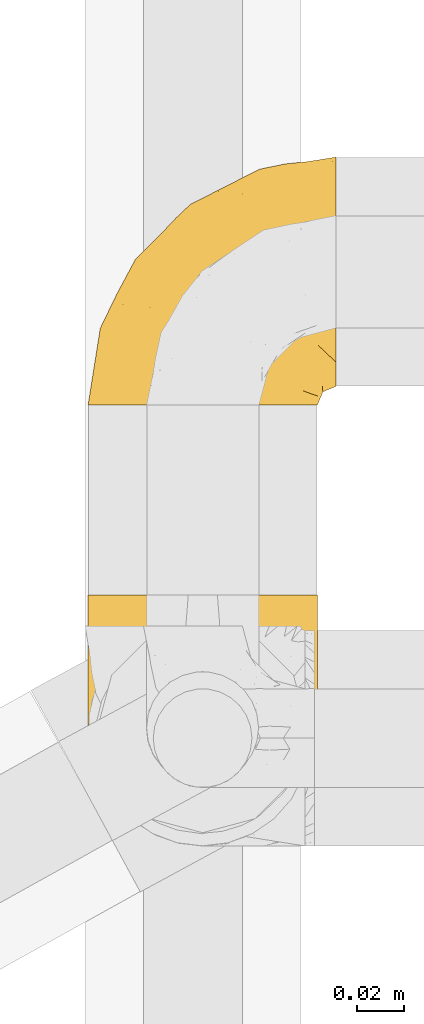
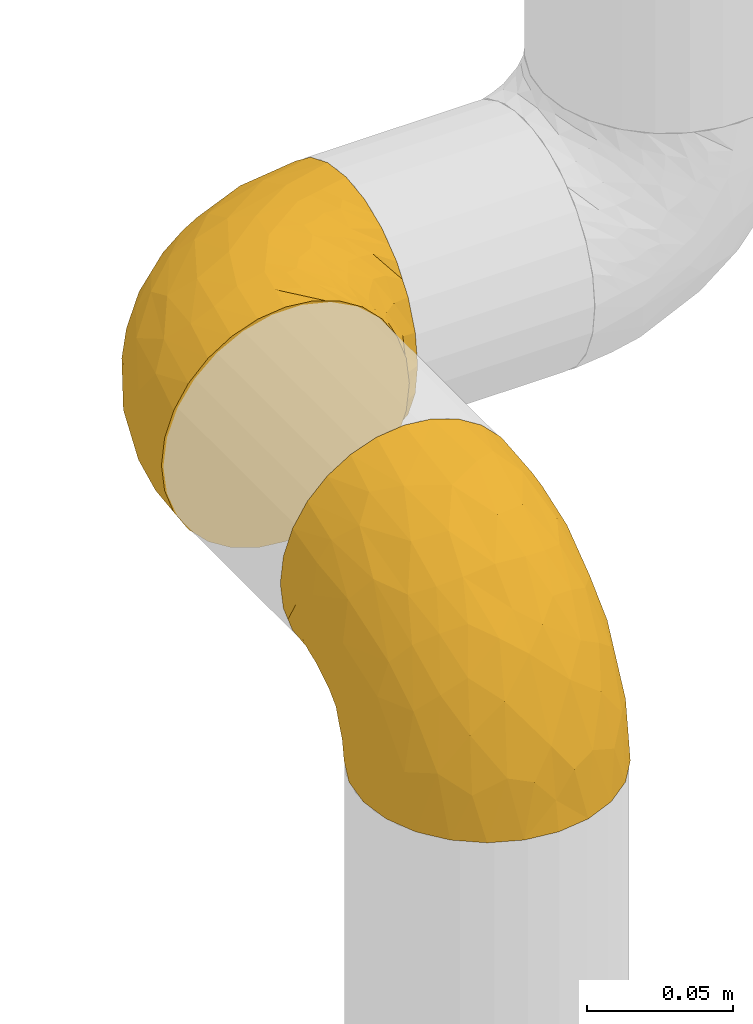
# One storey, part 168 of 827: 2 coverings.
"""IFC2X3 building model written with IfcOpenShell, lengths in millimetres."""

from ifc_helpers import new_model, entity, si_unit, converted_unit, derived_unit, direction, frame, origin, place, context, subcontext, project, spatial, faceted_brep, element, save


model = new_model("IFC2X3")

# Units and contexts
model_context = context("Model", 3, precision=0.01, world=origin(), true_north=direction((6.12303176911189e-17, 1.0)))
body_context = subcontext(model_context, "Body", "Model", "MODEL_VIEW")
ifc_project = project(units=[si_unit("LENGTHUNIT", "METRE", prefix="MILLI"), si_unit("AREAUNIT", "SQUARE_METRE"), si_unit("VOLUMEUNIT", "CUBIC_METRE"), converted_unit("PLANEANGLEUNIT", "DEGREE", entity("IfcRatioMeasure", 0.0174532925199433), si_unit("PLANEANGLEUNIT", "RADIAN"), dimensions=[0, 0, 0, 0, 0, 0, 0]), si_unit("MASSUNIT", "GRAM", prefix="KILO"), derived_unit("MASSDENSITYUNIT", [(si_unit("MASSUNIT", "GRAM", prefix="KILO"), 1), (si_unit("LENGTHUNIT", "METRE"), -3)]), derived_unit("MOMENTOFINERTIAUNIT", [(si_unit("LENGTHUNIT", "METRE"), 4)]), si_unit("TIMEUNIT", "SECOND"), si_unit("FREQUENCYUNIT", "HERTZ"), si_unit("THERMODYNAMICTEMPERATUREUNIT", "DEGREE_CELSIUS"), derived_unit("THERMALTRANSMITTANCEUNIT", [(si_unit("MASSUNIT", "GRAM", prefix="KILO"), 1), (si_unit("THERMODYNAMICTEMPERATUREUNIT", "KELVIN"), -1), (si_unit("TIMEUNIT", "SECOND"), -3)]), derived_unit("VOLUMETRICFLOWRATEUNIT", [(si_unit("LENGTHUNIT", "METRE"), 3), (si_unit("TIMEUNIT", "SECOND"), -1)]), derived_unit("MASSFLOWRATEUNIT", [(si_unit("MASSUNIT", "GRAM", prefix="KILO"), 1), (si_unit("TIMEUNIT", "SECOND"), -1)]), derived_unit("ROTATIONALFREQUENCYUNIT", [(si_unit("TIMEUNIT", "SECOND"), -1)]), si_unit("ELECTRICCURRENTUNIT", "AMPERE"), si_unit("ELECTRICVOLTAGEUNIT", "VOLT"), si_unit("POWERUNIT", "WATT"), si_unit("FORCEUNIT", "NEWTON", prefix="KILO"), si_unit("ILLUMINANCEUNIT", "LUX"), si_unit("LUMINOUSFLUXUNIT", "LUMEN"), si_unit("LUMINOUSINTENSITYUNIT", "CANDELA"), derived_unit("USERDEFINED", [(si_unit("MASSUNIT", "GRAM", prefix="KILO"), -1), (si_unit("LENGTHUNIT", "METRE"), -2), (si_unit("TIMEUNIT", "SECOND"), 3), (si_unit("LUMINOUSFLUXUNIT", "LUMEN"), 1)]), derived_unit("LINEARVELOCITYUNIT", [(si_unit("LENGTHUNIT", "METRE"), 1), (si_unit("TIMEUNIT", "SECOND"), -1)]), si_unit("PRESSUREUNIT", "PASCAL"), derived_unit("USERDEFINED", [(si_unit("LENGTHUNIT", "METRE"), -2), (si_unit("MASSUNIT", "GRAM", prefix="KILO"), 1), (si_unit("TIMEUNIT", "SECOND"), -2)]), derived_unit("LINEARFORCEUNIT", [(si_unit("MASSUNIT", "GRAM", prefix="KILO"), 1), (si_unit("LENGTHUNIT", "METRE"), 1), (si_unit("TIMEUNIT", "SECOND"), -2), (si_unit("LENGTHUNIT", "METRE"), -1)]), derived_unit("PLANARFORCEUNIT", [(si_unit("MASSUNIT", "GRAM", prefix="KILO"), 1), (si_unit("LENGTHUNIT", "METRE"), 1), (si_unit("TIMEUNIT", "SECOND"), -2), (si_unit("LENGTHUNIT", "METRE"), -2)])], contexts=[model_context])

# Site, building, storey
site_placement = place(None, origin())
site = spatial("IfcSite", under=ifc_project, at=site_placement, CompositionType="ELEMENT")
building_placement = place(site_placement, origin())
building = spatial("IfcBuilding", under=site, at=building_placement, CompositionType="ELEMENT")
storey_placement = place(building_placement, frame((0.0, 0.0, 28200.0)))
storey = spatial("IfcBuildingStorey", under=building, at=storey_placement, Name="08", CompositionType="ELEMENT", Elevation=28200.0)

# Coverings
covering_1_placement = place(storey_placement, frame((35683.5, 12959.74, 2541.4)))
element("IfcCovering", 1, at=covering_1_placement, inside=storey, Name=":ADSK_", ObjectType=":ADSK_", PredefinedType="INSULATION", context=body_context, shape_type="Brep", body=[
    faceted_brep([(1.6, 107.75, 58.6), (2.83, 107.75, 69.54), (6.47, 107.75, 79.93), (12.32, 107.75, 89.25), (20.11, 107.75, 97.03), (29.43, 107.75, 102.88), (39.81, 107.75, 106.51), (50.75, 107.75, 107.75), (61.69, 107.75, 106.51), (72.08, 107.75, 102.87), (81.4, 107.75, 97.02), (89.18, 107.75, 89.23), (95.03, 107.75, 79.91), (98.66, 107.75, 69.53), (99.9, 107.75, 58.6), (99.25, 107.75, 52.89), (98.66, 107.75, 47.65), (96.84, 107.75, 42.46), (95.02, 107.75, 37.26), (89.17, 107.75, 27.94), (81.38, 107.75, 20.16), (72.06, 107.75, 14.31), (61.68, 107.75, 10.68), (50.75, 107.75, 9.45), (39.8, 107.75, 10.68), (29.41, 107.75, 14.32), (20.09, 107.75, 20.17), (12.31, 107.75, 27.96), (6.46, 107.75, 37.28), (4.64, 107.75, 42.47), (2.83, 107.75, 47.66), (2.24, 107.75, 52.89), (1.92, 107.75, 55.75), (63.47, 98.22, 1.6), (75.32, 93.31, 1.6), (80.41, 89.4, 1.6), (85.5, 85.5, 1.6), (89.4, 80.41, 1.6), (93.31, 75.32, 1.6), (95.77, 69.39, 1.6), (98.22, 63.47, 1.6), (99.14, 56.48, 1.6), (99.52, 53.61, 1.6), (99.9, 50.75, 1.6), (98.22, 38.02, 1.6), (93.31, 26.17, 1.6), (85.5, 15.99, 1.6), (75.32, 8.18, 1.6), (63.47, 3.27, 1.6), (50.75, 1.6, 1.6), (38.02, 3.27, 1.6), (26.17, 8.18, 1.6), (15.99, 15.99, 1.6), (8.18, 26.17, 1.6), (3.27, 38.02, 1.6), (1.6, 50.75, 1.6), (2.35, 56.48, 1.6), (3.27, 63.47, 1.6), (5.73, 69.39, 1.6), (8.18, 75.32, 1.6), (12.09, 80.41, 1.6), (15.99, 85.5, 1.6), (21.08, 89.4, 1.6), (26.17, 93.31, 1.6), (38.02, 98.22, 1.6), (50.75, 99.9, 1.6), (42.18, 27.53, 69.96), (28.42, 25.32, 59.59), (37.78, 16.29, 51.96), (50.75, 6.79, 34.4), (42.85, 4.51, 23.37), (50.75, 3.51, 13.68), (24.75, 17.47, 41.52), (33.81, 7.6, 26.26), (22.57, 12.27, 20.18), (7.18, 70.89, 72.33), (2.73, 87.17, 65.88), (3.09, 67.3, 57.55), (6.92, 31.65, 23.76), (11.58, 33.58, 46.5), (5.17, 47.23, 46.57), (2.71, 43.26, 21.17), (1.6, 55.08, 23.41), (1.6, 53.99, 17.92), (1.6, 52.9, 12.43), (1.6, 52.36, 9.72), (1.6, 51.82, 7.01), (14.18, 21.5, 26.77), (5.88, 89.94, 76.59), (41.06, 60.45, 95.55), (36.25, 83.0, 102.57), (28.62, 64.79, 92.89), (1.6, 85.93, 54.26), (1.6, 81.31, 51.17), (1.6, 76.69, 48.08), (1.6, 72.06, 44.99), (1.6, 67.44, 41.9), (10.85, 88.74, 85.16), (38.35, 45.98, 85.97), (9.6, 47.13, 59.58), (26.24, 89.4, 99.5), (50.75, 95.66, 105.83), (19.31, 28.5, 53.59), (16.41, 42.81, 67.0), (24.56, 38.28, 71.56), (50.75, 45.35, 87.47), (50.75, 33.61, 75.73), (18.47, 82.57, 92.24), (1.6, 105.04, 58.06), (1.6, 102.33, 57.52), (1.6, 96.91, 56.44), (1.6, 91.42, 55.35), (14.36, 65.92, 81.33), (20.64, 53.11, 80.35), (2.32, 54.37, 39.44), (50.75, 74.94, 102.55), (1.6, 64.35, 37.28), (1.6, 61.26, 32.65), (1.6, 58.17, 28.03), (50.75, 21.87, 63.99), (33.88, 34.79, 74.55), (29.24, 48.48, 83.62), (50.75, 60.15, 95.01), (50.75, 14.33, 49.19), (2.8, 99.07, 46.96), (2.48, 60.55, 8.77), (2.7, 64.18, 18.28), (3.2, 64.36, 11.68), (32.98, 103.17, 11.79), (24.67, 101.69, 15.69), (2.95, 87.75, 42.49), (2.19, 89.38, 47.41), (17.92, 88.34, 7.94), (12.02, 82.14, 9.27), (25.73, 94.51, 7.98), (16.63, 89.64, 13.4), (25.6, 98.41, 13.04), (36.72, 99.71, 7.36), (10.66, 89.37, 23.46), (6.87, 88.21, 30.46), (11.12, 95.2, 26.54), (10.31, 79.14, 6.76), (12.84, 101.22, 26.46), (17.38, 99.41, 20.77), (9.74, 84.72, 20.68), (4.63, 97.47, 40.26), (50.75, 102.19, 7.15), (42.52, 104.02, 9.28), (3.12, 82.66, 38.78), (17.58, 95.42, 18.27), (3.97, 78.67, 31.78), (5.94, 72.69, 12.75), (2.73, 66.46, 22.96), (6.23, 75.3, 17.55), (3.45, 72.74, 27.63), (10.84, 82.93, 15.23), (7.98, 99.27, 33.25), (7.33, 93.51, 32.43), (2.39, 67.35, 27.9), (75.76, 94.51, 7.97), (90.65, 82.94, 15.22), (83.57, 88.33, 7.93), (84.85, 89.64, 13.38), (71.05, 103.62, 13.12), (98.54, 87.74, 42.49), (99.3, 89.38, 47.4), (99.9, 81.31, 51.17), (96.86, 97.47, 40.24), (84.1, 99.41, 20.76), (99.9, 52.9, 12.43), (99.9, 51.82, 7.01), (99.9, 51.28, 4.31), (88.63, 101.21, 26.44), (90.36, 95.19, 26.52), (98.29, 64.36, 11.68), (95.55, 72.69, 12.75), (89.47, 82.13, 9.27), (95.26, 75.3, 17.55), (91.18, 79.14, 6.76), (93.49, 99.28, 33.21), (94.15, 93.51, 32.41), (99.01, 60.55, 8.77), (98.76, 66.46, 22.96), (98.85, 63.96, 18.48), (99.9, 96.91, 56.44), (98.69, 99.06, 46.95), (64.78, 99.7, 7.36), (99.9, 53.99, 17.92), (99.9, 55.08, 23.41), (62.91, 103.3, 9.85), (99.9, 102.33, 57.52), (99.9, 99.62, 56.98), (99.9, 76.69, 48.08), (98.37, 82.66, 38.78), (83.9, 95.42, 18.25), (99.9, 72.06, 44.99), (97.51, 78.68, 31.74), (94.62, 88.2, 30.45), (98.04, 72.75, 27.63), (91.73, 84.74, 20.65), (99.9, 91.42, 55.35), (99.9, 85.93, 54.26), (75.87, 98.41, 13.03), (90.83, 89.37, 23.44), (99.1, 67.35, 27.9), (99.9, 61.26, 32.65), (99.9, 58.17, 28.03), (99.9, 64.35, 37.28), (99.9, 67.44, 41.9), (99.09, 54.08, 39.74), (58.64, 4.51, 23.37), (87.31, 21.5, 26.77), (89.93, 33.43, 46.18), (82.22, 28.5, 53.54), (76.74, 17.47, 41.53), (73.12, 25.36, 59.61), (95.54, 90.18, 76.79), (98.7, 86.97, 66.11), (98.79, 43.26, 21.17), (63.71, 16.29, 51.96), (67.68, 7.6, 26.26), (78.92, 12.27, 20.18), (94.57, 31.65, 23.76), (72.88, 64.79, 92.88), (65.25, 83.0, 102.57), (60.44, 60.44, 95.54), (76.94, 38.35, 71.63), (67.61, 34.8, 74.55), (94.38, 71.54, 72.51), (59.31, 27.53, 69.96), (83.03, 82.57, 92.23), (90.66, 88.74, 85.15), (80.8, 53.19, 80.45), (72.22, 48.49, 83.65), (98.39, 67.28, 57.57), (92.31, 52.32, 63.68), (63.11, 45.94, 85.95), (75.27, 89.4, 99.49), (87.15, 65.75, 81.23), (96.03, 46.73, 47.07), (85.1, 42.82, 66.99)], [[[0, 1, 2, 3, 4, 5, 6, 7, 8, 9, 10, 11, 12, 13, 14, 15, 16, 17, 18, 19, 20, 21, 22, 23, 24, 25, 26, 27, 28, 29, 30, 31, 32]], [[33, 34, 35, 36, 37, 38, 39, 40, 41, 42, 43, 44, 45, 46, 47, 48, 49, 50, 51, 52, 53, 54, 55, 56, 57, 58, 59, 60, 61, 62, 63, 64, 65]], [[66, 67, 68]], [[69, 70, 71]], [[68, 72, 73]], [[73, 72, 74]], [[75, 76, 77]], [[78, 79, 80]], [[51, 50, 73]], [[81, 82, 83, 84, 85, 86, 55]], [[52, 87, 53]], [[74, 52, 51]], [[2, 1, 88]], [[89, 90, 91]], [[77, 92, 93, 94, 95, 96]], [[55, 54, 81]], [[78, 53, 87]], [[5, 90, 6]], [[88, 76, 75]], [[97, 3, 2]], [[89, 91, 98]], [[99, 80, 79]], [[90, 5, 100]], [[74, 87, 52]], [[100, 5, 4]], [[90, 101, 6]], [[79, 102, 103]], [[102, 67, 104]], [[105, 98, 106]], [[107, 4, 3]], [[76, 0, 108, 109, 110, 111, 92]], [[107, 112, 113]], [[114, 77, 96]], [[89, 115, 90]], [[114, 96, 116, 117, 118, 82]], [[75, 97, 88]], [[119, 66, 68]], [[50, 71, 70]], [[100, 91, 90]], [[99, 77, 80]], [[102, 104, 103]], [[97, 107, 3]], [[80, 81, 78]], [[107, 97, 112]], [[68, 73, 70]], [[66, 98, 120]], [[78, 81, 54]], [[114, 81, 80]], [[53, 78, 54]], [[78, 87, 79]], [[102, 87, 72]], [[79, 103, 99]], [[4, 107, 100]], [[91, 100, 107]], [[88, 97, 2]], [[112, 97, 75]], [[99, 112, 75]], [[103, 104, 113]], [[91, 121, 98]], [[89, 105, 122, 115]], [[101, 90, 115]], [[101, 7, 6]], [[88, 1, 76]], [[0, 76, 1]], [[92, 77, 76]], [[73, 74, 51]], [[87, 74, 72]], [[81, 114, 82]], [[77, 114, 80]], [[87, 102, 79]], [[67, 102, 72]], [[68, 67, 72]], [[67, 120, 104]], [[120, 121, 104]], [[104, 121, 113]], [[121, 120, 98]], [[91, 107, 113]], [[91, 113, 121]], [[103, 113, 112]], [[106, 98, 66]], [[105, 89, 98]], [[106, 66, 119]], [[67, 66, 120]], [[68, 69, 123, 119]], [[50, 49, 71]], [[50, 70, 73]], [[112, 99, 103]], [[77, 99, 75]], [[69, 68, 70]], [[29, 124, 110]], [[84, 83, 125]], [[126, 82, 118]], [[59, 58, 127]], [[25, 128, 129]], [[130, 93, 131]], [[132, 62, 133]], [[134, 135, 136]], [[137, 65, 64]], [[64, 134, 137]], [[138, 139, 140]], [[111, 110, 124, 92]], [[134, 136, 137]], [[134, 64, 63]], [[141, 61, 60]], [[125, 58, 57]], [[142, 143, 140]], [[142, 26, 143]], [[127, 83, 82]], [[28, 124, 29]], [[108, 0, 32, 31, 30, 110, 109]], [[30, 29, 110]], [[135, 144, 138]], [[28, 145, 124]], [[57, 56, 55, 86, 85, 84]], [[146, 147, 23]], [[24, 23, 147]], [[25, 143, 26]], [[95, 94, 148]], [[24, 128, 25]], [[149, 138, 143]], [[124, 145, 131]], [[127, 58, 125]], [[150, 148, 139]], [[127, 126, 151]], [[151, 59, 127]], [[152, 151, 126]], [[153, 154, 155]], [[153, 133, 141]], [[145, 28, 27]], [[142, 156, 27]], [[157, 148, 130]], [[61, 133, 62]], [[134, 132, 135]], [[147, 128, 24]], [[65, 137, 146]], [[146, 137, 147]], [[128, 137, 136]], [[137, 128, 147]], [[128, 136, 129]], [[149, 129, 136]], [[25, 129, 143]], [[158, 152, 117]], [[152, 118, 117]], [[153, 151, 152]], [[158, 116, 154]], [[144, 150, 138]], [[153, 152, 158]], [[133, 153, 155]], [[133, 155, 132]], [[141, 60, 151]], [[135, 132, 155]], [[134, 63, 132]], [[144, 135, 155]], [[135, 138, 149]], [[155, 154, 144]], [[150, 154, 96]], [[154, 150, 144]], [[148, 94, 130]], [[82, 126, 127]], [[118, 152, 126]], [[150, 96, 95]], [[139, 148, 157]], [[150, 95, 148]], [[93, 92, 131]], [[130, 145, 156]], [[130, 94, 93]], [[84, 125, 57]], [[127, 125, 83]], [[140, 139, 157]], [[150, 139, 138]], [[140, 157, 142]], [[138, 140, 143]], [[156, 142, 157]], [[27, 26, 142]], [[130, 156, 157]], [[145, 27, 156]], [[132, 63, 62]], [[124, 131, 92]], [[130, 131, 145]], [[129, 149, 143]], [[135, 149, 136]], [[153, 141, 151]], [[59, 151, 60]], [[133, 61, 141]], [[116, 96, 154]], [[153, 158, 154]], [[158, 117, 116]], [[34, 33, 159]], [[160, 161, 162]], [[22, 21, 163]], [[164, 165, 166]], [[19, 18, 167]], [[168, 21, 20]], [[42, 41, 40, 169, 170, 171, 43]], [[172, 173, 168]], [[174, 38, 175]], [[176, 177, 178]], [[179, 164, 180]], [[40, 181, 169]], [[182, 183, 175]], [[17, 184, 185]], [[65, 146, 186]], [[187, 174, 188]], [[23, 22, 189]], [[174, 39, 38]], [[15, 14, 190, 191, 184, 16]], [[181, 40, 39]], [[192, 193, 164]], [[194, 163, 168]], [[33, 186, 159]], [[180, 173, 172]], [[195, 196, 193]], [[18, 185, 167]], [[173, 180, 197]], [[198, 199, 196]], [[200, 201, 185, 184]], [[184, 17, 16]], [[18, 17, 185]], [[202, 159, 186]], [[194, 168, 203]], [[189, 163, 202]], [[204, 205, 182]], [[187, 181, 174]], [[160, 177, 176]], [[206, 183, 182]], [[206, 182, 205]], [[201, 165, 185]], [[165, 164, 167]], [[172, 179, 180]], [[202, 194, 162]], [[176, 161, 160]], [[65, 186, 33]], [[163, 189, 22]], [[175, 177, 182]], [[174, 183, 188]], [[177, 198, 204]], [[199, 160, 162]], [[198, 207, 204]], [[175, 38, 37]], [[198, 177, 160]], [[178, 177, 175]], [[176, 35, 161]], [[34, 159, 161]], [[162, 161, 159]], [[202, 162, 159]], [[199, 162, 203]], [[196, 199, 203]], [[198, 160, 199]], [[193, 197, 180]], [[208, 198, 196]], [[188, 183, 206]], [[175, 183, 174]], [[193, 192, 195]], [[195, 208, 196]], [[197, 196, 203]], [[180, 164, 193]], [[168, 163, 21]], [[166, 165, 201]], [[166, 192, 164]], [[189, 202, 186]], [[186, 146, 189]], [[23, 189, 146]], [[174, 181, 39]], [[169, 181, 187]], [[196, 197, 193]], [[173, 203, 168]], [[203, 173, 197]], [[172, 168, 20]], [[20, 19, 172]], [[179, 172, 19]], [[19, 167, 179]], [[164, 179, 167]], [[35, 176, 36]], [[35, 34, 161]], [[185, 165, 167]], [[162, 194, 203]], [[163, 194, 202]], [[176, 178, 36]], [[37, 36, 178]], [[175, 37, 178]], [[177, 204, 182]], [[207, 198, 208]], [[207, 205, 204]], [[209, 188, 206, 205, 207, 208]], [[48, 210, 71]], [[211, 212, 213]], [[214, 213, 215]], [[216, 217, 13]], [[218, 43, 171, 170, 169, 187, 188]], [[219, 220, 214]], [[47, 46, 221]], [[210, 48, 220]], [[211, 222, 212]], [[222, 45, 44]], [[221, 220, 47]], [[47, 220, 48]], [[221, 211, 214]], [[223, 224, 225]], [[211, 46, 45]], [[226, 227, 215]], [[43, 218, 44]], [[217, 216, 228]], [[219, 215, 229]], [[14, 13, 217]], [[224, 9, 8]], [[10, 230, 11]], [[11, 231, 12]], [[232, 223, 233]], [[234, 208, 195, 192, 166, 201]], [[235, 234, 228]], [[222, 44, 218]], [[106, 229, 236]], [[224, 237, 9]], [[231, 238, 228]], [[9, 237, 10]], [[115, 224, 101]], [[239, 234, 235]], [[231, 11, 230]], [[223, 230, 237]], [[224, 8, 101]], [[223, 236, 233]], [[225, 115, 122, 105]], [[216, 12, 231]], [[209, 234, 239]], [[210, 219, 69]], [[219, 214, 215]], [[229, 119, 219]], [[209, 218, 188]], [[239, 212, 222]], [[239, 222, 218]], [[45, 222, 211]], [[235, 212, 239]], [[213, 212, 240]], [[223, 237, 224]], [[230, 10, 237]], [[238, 231, 230]], [[216, 231, 228]], [[232, 230, 223]], [[235, 238, 240]], [[115, 225, 224]], [[233, 236, 227]], [[8, 7, 101]], [[234, 209, 208]], [[218, 209, 239]], [[217, 228, 234]], [[13, 12, 216]], [[234, 201, 217]], [[217, 201, 200, 184, 191, 190, 14]], [[211, 221, 46]], [[220, 221, 214]], [[71, 210, 69]], [[71, 49, 48]], [[219, 210, 220]], [[226, 215, 213]], [[211, 213, 214]], [[226, 213, 240]], [[215, 227, 229]], [[232, 240, 238]], [[233, 227, 226]], [[232, 233, 226]], [[236, 223, 225]], [[240, 232, 226]], [[232, 238, 230]], [[225, 105, 236]], [[236, 105, 106]], [[236, 229, 227]], [[123, 69, 219, 119]], [[106, 119, 229]], [[238, 235, 228]], [[212, 235, 240]]]),
])
covering_2_placement = place(storey_placement, frame((35683.5, 13147.49, 2549.25)))
element("IfcCovering", 2, at=covering_2_placement, inside=storey, Name=":ADSK_", ObjectType=":ADSK_", PredefinedType="INSULATION", context=body_context, shape_type="Brep", body=[
    faceted_brep([(50.75, 1.6, 99.9), (39.8, 1.6, 98.66), (29.41, 1.6, 95.02), (20.09, 1.6, 89.17), (12.31, 1.6, 81.38), (6.46, 1.6, 72.06), (2.83, 1.6, 61.68), (1.6, 1.6, 50.75), (2.83, 1.6, 39.8), (6.47, 1.6, 29.41), (12.32, 1.6, 20.09), (20.11, 1.6, 12.31), (29.43, 1.6, 6.46), (39.81, 1.6, 2.83), (50.75, 1.6, 1.6), (56.45, 1.6, 2.24), (61.69, 1.6, 2.83), (66.88, 1.6, 4.65), (72.08, 1.6, 6.47), (81.4, 1.6, 12.32), (89.18, 1.6, 20.11), (95.03, 1.6, 29.43), (98.66, 1.6, 39.81), (99.9, 1.6, 50.75), (98.66, 1.6, 61.69), (95.02, 1.6, 72.08), (89.17, 1.6, 81.4), (81.38, 1.6, 89.18), (72.06, 1.6, 95.03), (66.87, 1.6, 96.85), (61.68, 1.6, 98.66), (56.45, 1.6, 99.25), (53.6, 1.6, 99.57), (107.75, 11.12, 38.02), (107.75, 16.03, 26.17), (107.75, 19.94, 21.08), (107.75, 23.84, 15.99), (107.75, 28.93, 12.09), (107.75, 34.02, 8.18), (107.75, 39.95, 5.73), (107.75, 45.87, 3.27), (107.75, 52.86, 2.35), (107.75, 55.73, 1.97), (107.75, 58.6, 1.6), (107.75, 71.32, 3.27), (107.75, 83.17, 8.18), (107.75, 93.35, 15.99), (107.75, 101.16, 26.17), (107.75, 106.07, 38.02), (107.75, 107.75, 50.75), (107.75, 106.07, 63.47), (107.75, 101.16, 75.32), (107.75, 93.35, 85.5), (107.75, 83.17, 93.31), (107.75, 71.32, 98.22), (107.75, 58.6, 99.9), (107.75, 52.86, 99.14), (107.75, 45.87, 98.22), (107.75, 39.95, 95.77), (107.75, 34.02, 93.31), (107.75, 28.93, 89.4), (107.75, 23.84, 85.5), (107.75, 19.94, 80.41), (107.75, 16.03, 75.32), (107.75, 11.12, 63.47), (107.75, 9.45, 50.75), (39.38, 81.82, 59.31), (49.75, 84.02, 73.08), (57.38, 93.05, 63.72), (74.94, 102.55, 50.75), (85.97, 104.83, 58.64), (95.66, 105.83, 50.75), (67.82, 91.87, 76.74), (83.09, 101.74, 67.68), (89.16, 97.07, 78.92), (37.01, 38.45, 94.31), (43.46, 22.17, 98.76), (51.79, 42.04, 98.4), (85.58, 77.69, 94.57), (62.84, 75.76, 89.91), (62.77, 62.11, 96.32), (88.17, 66.08, 98.79), (85.93, 54.26, 99.9), (91.42, 55.35, 99.9), (96.91, 56.44, 99.9), (99.62, 56.98, 99.9), (102.33, 57.52, 99.9), (82.57, 87.84, 87.31), (32.75, 19.41, 95.61), (13.79, 48.89, 60.43), (6.77, 26.34, 65.24), (16.46, 44.55, 72.87), (55.08, 23.41, 99.9), (58.17, 28.03, 99.9), (61.26, 32.65, 99.9), (64.35, 37.28, 99.9), (67.44, 41.9, 99.9), (24.18, 20.6, 90.65), (23.37, 63.36, 63.14), (49.76, 62.21, 91.89), (9.84, 19.94, 75.25), (3.51, 13.68, 50.75), (55.75, 80.85, 82.18), (42.34, 66.53, 85.08), (37.78, 71.06, 76.93), (21.87, 63.99, 50.75), (33.61, 75.73, 50.75), (17.1, 26.77, 83.02), (51.28, 4.31, 99.9), (51.82, 7.01, 99.9), (52.9, 12.43, 99.9), (53.99, 17.92, 99.9), (28.01, 43.43, 87.13), (28.99, 56.23, 80.85), (69.9, 54.97, 99.17), (6.79, 34.4, 50.75), (72.06, 44.99, 99.9), (76.69, 48.08, 99.9), (81.31, 51.17, 99.9), (45.35, 87.47, 50.75), (34.79, 74.55, 67.61), (25.72, 60.86, 72.25), (14.33, 49.19, 50.75), (60.15, 95.01, 50.75), (62.38, 10.27, 98.69), (100.57, 48.79, 99.01), (91.06, 45.16, 98.79), (97.66, 44.99, 98.29), (97.55, 6.17, 68.51), (93.65, 7.65, 76.82), (66.85, 21.59, 98.54), (61.93, 19.96, 99.3), (101.4, 21.0, 83.57), (100.07, 27.2, 89.47), (101.36, 14.83, 75.76), (95.94, 19.7, 84.86), (96.3, 10.93, 75.89), (101.98, 9.63, 64.77), (85.88, 19.97, 90.83), (78.88, 21.13, 94.62), (82.8, 14.14, 90.37), (102.58, 30.2, 91.18), (82.88, 8.12, 88.65), (88.57, 9.93, 84.11), (88.67, 24.62, 91.75), (69.08, 11.87, 96.86), (102.19, 7.15, 50.75), (100.06, 5.32, 58.97), (70.56, 26.68, 98.37), (91.07, 13.92, 83.91), (77.56, 30.67, 97.52), (96.59, 36.65, 95.55), (86.38, 42.89, 98.76), (91.79, 34.04, 95.26), (81.71, 36.6, 98.04), (94.11, 26.41, 90.65), (76.09, 10.07, 93.51), (76.91, 15.83, 94.16), (81.44, 41.99, 99.1), (101.37, 14.83, 25.73), (94.12, 26.4, 10.84), (101.41, 21.01, 17.92), (95.96, 19.71, 16.64), (96.22, 5.72, 30.44), (66.85, 21.6, 2.95), (61.94, 19.96, 2.19), (58.17, 28.03, 1.6), (69.1, 11.87, 4.63), (88.58, 9.93, 17.39), (96.91, 56.44, 1.6), (102.33, 57.52, 1.6), (105.04, 58.06, 1.6), (82.9, 8.13, 12.86), (82.82, 14.15, 11.13), (97.66, 44.99, 3.2), (96.59, 36.65, 5.94), (100.07, 27.21, 12.02), (91.79, 34.04, 6.23), (102.58, 30.2, 10.31), (76.13, 10.06, 8.0), (76.93, 15.83, 7.34), (100.57, 48.79, 2.48), (86.38, 42.89, 2.73), (90.86, 45.38, 2.64), (52.9, 12.43, 1.6), (62.39, 10.28, 2.8), (101.98, 9.64, 36.71), (91.42, 55.35, 1.6), (85.93, 54.26, 1.6), (99.49, 6.05, 38.59), (51.82, 7.01, 1.6), (52.36, 9.72, 1.6), (61.26, 32.65, 1.6), (70.56, 26.68, 3.12), (91.09, 13.92, 17.59), (64.35, 37.28, 1.6), (77.6, 30.66, 3.98), (78.89, 21.14, 6.87), (81.71, 36.59, 3.45), (88.69, 24.6, 9.76), (53.99, 17.92, 1.6), (55.08, 23.41, 1.6), (96.31, 10.93, 25.62), (85.9, 19.97, 10.67), (81.45, 41.99, 2.39), (76.69, 48.08, 1.6), (81.31, 51.17, 1.6), (72.06, 44.99, 1.6), (67.44, 41.9, 1.6), (69.6, 55.26, 2.4), (85.97, 104.83, 42.85), (82.57, 87.84, 14.18), (63.16, 75.91, 11.56), (55.81, 80.84, 19.27), (67.81, 91.87, 24.75), (49.73, 83.98, 28.37), (32.55, 19.16, 5.95), (43.23, 22.37, 2.79), (88.17, 66.08, 2.71), (57.38, 93.05, 37.78), (83.08, 101.74, 33.81), (89.16, 97.07, 22.57), (85.58, 77.69, 6.92), (16.46, 44.55, 28.61), (6.77, 26.34, 36.24), (13.8, 48.9, 41.05), (37.71, 70.99, 24.55), (34.8, 74.55, 33.88), (36.83, 37.8, 7.11), (39.38, 81.82, 42.18), (17.12, 26.77, 18.46), (24.19, 20.6, 10.84), (28.89, 56.15, 20.69), (25.69, 60.85, 29.27), (51.77, 42.06, 3.1), (45.66, 57.03, 9.18), (23.39, 63.4, 38.38), (9.85, 19.94, 26.23), (28.11, 43.59, 14.34), (62.27, 62.61, 5.46), (42.35, 66.52, 16.39)], [[[0, 1, 2, 3, 4, 5, 6, 7, 8, 9, 10, 11, 12, 13, 14, 15, 16, 17, 18, 19, 20, 21, 22, 23, 24, 25, 26, 27, 28, 29, 30, 31, 32]], [[33, 34, 35, 36, 37, 38, 39, 40, 41, 42, 43, 44, 45, 46, 47, 48, 49, 50, 51, 52, 53, 54, 55, 56, 57, 58, 59, 60, 61, 62, 63, 64, 65]], [[66, 67, 68]], [[69, 70, 71]], [[68, 72, 73]], [[73, 72, 74]], [[75, 76, 77]], [[78, 79, 80]], [[51, 50, 73]], [[81, 82, 83, 84, 85, 86, 55]], [[52, 87, 53]], [[74, 52, 51]], [[2, 1, 88]], [[89, 90, 91]], [[77, 92, 93, 94, 95, 96]], [[55, 54, 81]], [[78, 53, 87]], [[5, 90, 6]], [[88, 76, 75]], [[97, 3, 2]], [[89, 91, 98]], [[99, 80, 79]], [[90, 5, 100]], [[74, 87, 52]], [[100, 5, 4]], [[90, 101, 6]], [[79, 102, 103]], [[102, 67, 104]], [[105, 98, 106]], [[107, 4, 3]], [[76, 0, 108, 109, 110, 111, 92]], [[107, 112, 113]], [[114, 77, 96]], [[89, 115, 90]], [[114, 96, 116, 117, 118, 82]], [[75, 97, 88]], [[119, 66, 68]], [[50, 71, 70]], [[100, 91, 90]], [[99, 77, 80]], [[102, 104, 103]], [[97, 107, 3]], [[80, 81, 78]], [[107, 97, 112]], [[68, 73, 70]], [[66, 98, 120]], [[78, 81, 54]], [[114, 81, 80]], [[53, 78, 54]], [[78, 87, 79]], [[102, 87, 72]], [[79, 103, 99]], [[4, 107, 100]], [[91, 100, 107]], [[88, 97, 2]], [[112, 97, 75]], [[99, 112, 75]], [[103, 104, 113]], [[91, 121, 98]], [[89, 105, 122, 115]], [[101, 90, 115]], [[101, 7, 6]], [[88, 1, 76]], [[0, 76, 1]], [[92, 77, 76]], [[73, 74, 51]], [[87, 74, 72]], [[81, 114, 82]], [[77, 114, 80]], [[87, 102, 79]], [[67, 102, 72]], [[68, 67, 72]], [[67, 120, 104]], [[120, 121, 104]], [[104, 121, 113]], [[121, 120, 98]], [[91, 107, 113]], [[91, 113, 121]], [[103, 113, 112]], [[106, 98, 66]], [[105, 89, 98]], [[106, 66, 119]], [[67, 66, 120]], [[68, 69, 123, 119]], [[50, 49, 71]], [[50, 70, 73]], [[112, 99, 103]], [[77, 99, 75]], [[69, 68, 70]], [[29, 124, 110]], [[84, 83, 125]], [[126, 82, 118]], [[59, 58, 127]], [[25, 128, 129]], [[130, 93, 131]], [[132, 62, 133]], [[134, 135, 136]], [[137, 65, 64]], [[64, 134, 137]], [[138, 139, 140]], [[111, 110, 124, 92]], [[134, 136, 137]], [[134, 64, 63]], [[141, 61, 60]], [[125, 58, 57]], [[142, 143, 140]], [[142, 26, 143]], [[127, 83, 82]], [[28, 124, 29]], [[108, 0, 32, 31, 30, 110, 109]], [[30, 29, 110]], [[135, 144, 138]], [[28, 145, 124]], [[57, 56, 55, 86, 85, 84]], [[146, 147, 23]], [[24, 23, 147]], [[25, 143, 26]], [[95, 94, 148]], [[24, 128, 25]], [[149, 138, 143]], [[124, 145, 131]], [[127, 58, 125]], [[150, 148, 139]], [[127, 126, 151]], [[151, 59, 127]], [[152, 151, 126]], [[153, 154, 155]], [[153, 133, 141]], [[145, 28, 27]], [[142, 156, 27]], [[157, 148, 130]], [[61, 133, 62]], [[134, 132, 135]], [[147, 128, 24]], [[65, 137, 146]], [[146, 137, 147]], [[128, 137, 136]], [[137, 128, 147]], [[128, 136, 129]], [[149, 129, 136]], [[25, 129, 143]], [[158, 152, 117]], [[152, 118, 117]], [[153, 151, 152]], [[158, 116, 154]], [[144, 150, 138]], [[153, 152, 158]], [[133, 153, 155]], [[133, 155, 132]], [[60, 151, 141]], [[135, 132, 155]], [[134, 63, 132]], [[144, 135, 155]], [[135, 138, 149]], [[155, 154, 144]], [[150, 154, 96]], [[154, 150, 144]], [[148, 94, 130]], [[82, 126, 127]], [[118, 152, 126]], [[150, 96, 95]], [[139, 148, 157]], [[150, 95, 148]], [[93, 92, 131]], [[130, 145, 156]], [[130, 94, 93]], [[84, 125, 57]], [[127, 125, 83]], [[140, 139, 157]], [[150, 139, 138]], [[140, 157, 142]], [[138, 140, 143]], [[156, 142, 157]], [[27, 26, 142]], [[130, 156, 157]], [[145, 27, 156]], [[132, 63, 62]], [[124, 131, 92]], [[130, 131, 145]], [[129, 149, 143]], [[135, 149, 136]], [[141, 133, 61]], [[60, 59, 151]], [[141, 151, 153]], [[116, 96, 154]], [[153, 158, 154]], [[158, 117, 116]], [[34, 33, 159]], [[160, 161, 162]], [[22, 21, 163]], [[164, 165, 166]], [[19, 18, 167]], [[168, 21, 20]], [[42, 41, 40, 169, 170, 171, 43]], [[172, 173, 168]], [[174, 38, 175]], [[176, 177, 178]], [[179, 164, 180]], [[40, 181, 169]], [[182, 183, 175]], [[17, 184, 185]], [[65, 146, 186]], [[187, 174, 188]], [[23, 22, 189]], [[174, 39, 38]], [[15, 14, 190, 191, 184, 16]], [[181, 40, 39]], [[192, 193, 164]], [[194, 163, 168]], [[33, 186, 159]], [[180, 173, 172]], [[195, 196, 193]], [[18, 185, 167]], [[173, 180, 197]], [[198, 199, 196]], [[200, 201, 185, 184]], [[184, 17, 16]], [[18, 17, 185]], [[202, 159, 186]], [[194, 168, 203]], [[189, 163, 202]], [[204, 205, 182]], [[187, 181, 174]], [[160, 177, 176]], [[206, 183, 182]], [[206, 182, 205]], [[201, 165, 185]], [[165, 164, 167]], [[172, 179, 180]], [[202, 194, 162]], [[176, 161, 160]], [[65, 186, 33]], [[163, 189, 22]], [[175, 177, 182]], [[174, 183, 188]], [[177, 198, 204]], [[199, 160, 162]], [[198, 207, 204]], [[175, 38, 37]], [[198, 177, 160]], [[178, 177, 175]], [[176, 35, 161]], [[34, 159, 161]], [[162, 161, 159]], [[202, 162, 159]], [[199, 162, 203]], [[196, 199, 203]], [[198, 160, 199]], [[193, 197, 180]], [[208, 198, 196]], [[188, 183, 206]], [[175, 183, 174]], [[193, 192, 195]], [[195, 208, 196]], [[197, 196, 203]], [[180, 164, 193]], [[168, 163, 21]], [[166, 165, 201]], [[166, 192, 164]], [[189, 202, 186]], [[186, 146, 189]], [[23, 189, 146]], [[174, 181, 39]], [[169, 181, 187]], [[196, 197, 193]], [[173, 203, 168]], [[203, 173, 197]], [[172, 168, 20]], [[20, 19, 172]], [[179, 172, 19]], [[19, 167, 179]], [[164, 179, 167]], [[35, 176, 36]], [[35, 34, 161]], [[185, 165, 167]], [[162, 194, 203]], [[163, 194, 202]], [[176, 178, 36]], [[37, 36, 178]], [[175, 37, 178]], [[177, 204, 182]], [[207, 198, 208]], [[207, 205, 204]], [[209, 188, 206, 205, 207, 208]], [[48, 210, 71]], [[211, 212, 213]], [[214, 213, 215]], [[216, 217, 13]], [[218, 43, 171, 170, 169, 187, 188]], [[219, 220, 214]], [[47, 46, 221]], [[210, 48, 220]], [[211, 222, 212]], [[222, 45, 44]], [[221, 220, 47]], [[47, 220, 48]], [[221, 211, 214]], [[223, 224, 225]], [[211, 46, 45]], [[226, 227, 215]], [[43, 218, 44]], [[217, 216, 228]], [[219, 215, 229]], [[14, 13, 217]], [[224, 9, 8]], [[10, 230, 11]], [[11, 231, 12]], [[232, 223, 233]], [[234, 208, 195, 192, 166, 201]], [[235, 234, 228]], [[222, 44, 218]], [[106, 229, 236]], [[224, 237, 9]], [[231, 238, 228]], [[9, 237, 10]], [[115, 224, 101]], [[239, 234, 235]], [[231, 11, 230]], [[223, 230, 237]], [[224, 8, 101]], [[223, 236, 233]], [[225, 115, 122, 105]], [[216, 12, 231]], [[209, 234, 239]], [[210, 219, 69]], [[219, 214, 215]], [[229, 119, 219]], [[209, 218, 188]], [[239, 212, 222]], [[239, 222, 218]], [[45, 222, 211]], [[235, 212, 239]], [[213, 212, 240]], [[223, 237, 224]], [[230, 10, 237]], [[238, 231, 230]], [[216, 231, 228]], [[232, 230, 223]], [[235, 238, 240]], [[115, 225, 224]], [[233, 236, 227]], [[8, 7, 101]], [[234, 209, 208]], [[218, 209, 239]], [[217, 228, 234]], [[13, 12, 216]], [[234, 201, 217]], [[217, 201, 200, 184, 191, 190, 14]], [[211, 221, 46]], [[220, 221, 214]], [[71, 210, 69]], [[71, 49, 48]], [[219, 210, 220]], [[226, 215, 213]], [[211, 213, 214]], [[226, 213, 240]], [[215, 227, 229]], [[232, 240, 238]], [[233, 227, 226]], [[232, 233, 226]], [[236, 223, 225]], [[240, 232, 226]], [[232, 238, 230]], [[225, 105, 236]], [[236, 105, 106]], [[236, 229, 227]], [[123, 69, 219, 119]], [[106, 119, 229]], [[238, 235, 228]], [[212, 235, 240]]]),
])

save(model, "model.ifc")
